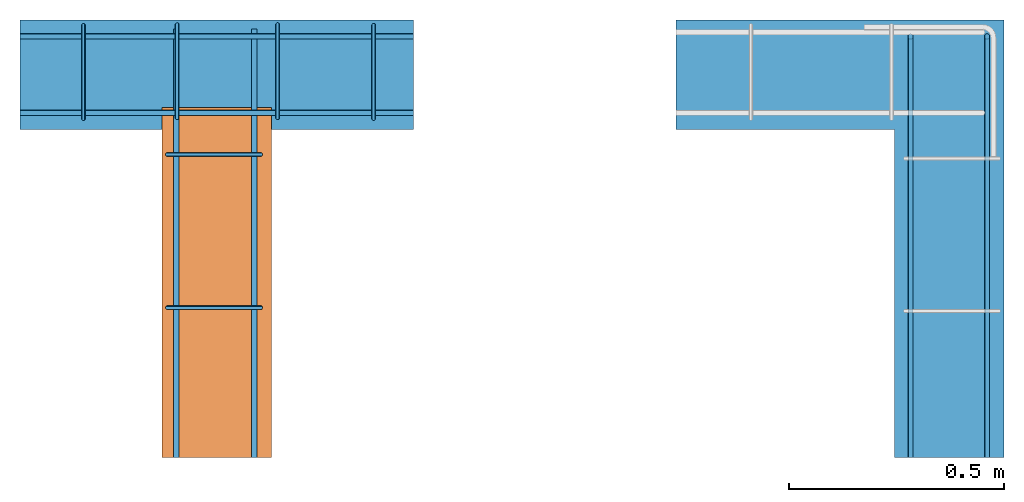
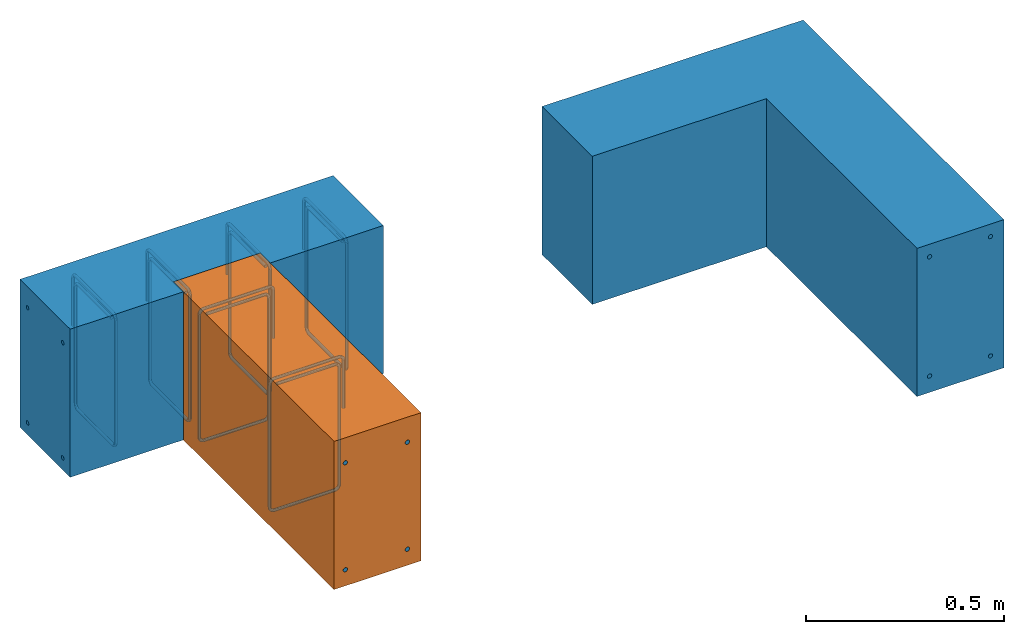
# One storey, part 1 of 2: 12 reinforcing bars, 2 walls, 1 proxy, 2 elements without a shape of their own.
"""IFC4 building model written with IfcOpenShell, lengths in metres."""

from ifc_helpers import new_model, entity, si_unit, converted_unit, direction, frame, frame_2d, origin_with_axes, origin_2d_with_axis, place, context, subcontext, project, spatial, polyline, rectangle, outline, extrude, element, aggregate, save


model = new_model("IFC4")

# Units and contexts
model_context = context("Model", 3, precision=1e-05, world=origin_with_axes(), true_north=direction((0.0, 1.0)))
body_context = subcontext(model_context, "Body", "Model", "MODEL_VIEW")
ifc_project = project(units=[si_unit("LENGTHUNIT", "METRE"), si_unit("AREAUNIT", "SQUARE_METRE"), si_unit("VOLUMEUNIT", "CUBIC_METRE"), converted_unit("PLANEANGLEUNIT", "DEGREE", entity("IfcPlaneAngleMeasure", 0.017453292519943295), si_unit("PLANEANGLEUNIT", "RADIAN"), dimensions=[0, 0, 0, 0, 0, 0, 0])], contexts=[model_context])

# Site, building, storey
site = spatial("IfcSite", under=ifc_project, CompositionType="ELEMENT")
building = spatial("IfcBuilding", under=site, Name="Default Building", CompositionType="ELEMENT")
storey = spatial("IfcBuildingStorey", under=building, Name="Detail 2", CompositionType="COMPLEX")

# Wall
placement = place(None, origin_with_axes())
wall_1 = element("IfcWall", 1, at=placement, inside=storey, Name="Wall", PredefinedType="MOVABLE", context=body_context, shape_type="SweptSolid", body=[
    extrude(rectangle(XDim=0.9144, YDim=0.254, at=origin_2d_with_axis()), frame((3.2004, -0.126999998486042, 0.0254), z_axis=(0.0, 0.0, 1.0), x_axis=(1.0, 0.0, 0.0)), (0.0, 0.0, -1.0), 0.4572),
])

element("IfcWall", 2, at=placement, inside=storey, Name="Wall", PredefinedType="MOVABLE", context=body_context, shape_type="SweptSolid", body=[
    extrude(outline(polyline([(-0.507999999999905, 0.380999999999986), (0.254, 0.381), (0.254, -0.635), (0.0, -0.635000000000024), (9.45910016980633e-14, 0.126999999999953), (-0.507999999999811, 0.126999999999962), (-0.507999999999905, 0.380999999999986)])), frame((4.7752, -0.380999998486042, 0.0254), z_axis=(0.0, 0.0, 1.0), x_axis=(1.0, 0.0, 0.0)), (0.0, 0.0, -1.0), 0.4572),
])

# Proxy
proxy = element("IfcBuildingElementProxy", 3, at=placement, Name="Wall", PredefinedType="ELEMENT", context=body_context, shape_type="SweptSolid", body=[
    extrude(rectangle(XDim=0.812800003051763, YDim=0.254, at=frame_2d((0.0, 0.0), x_axis=(-1.20147944482968e-07, 0.999999999999993))), frame((3.20039995117188, -0.609599998474121, 0.0254), z_axis=(0.0, 0.0, 1.0), x_axis=(1.0, 0.0, 0.0)), (0.0, 0.0, -1.0), 0.4572),
])

aggregate(wall_1, [proxy])

# Assembly, reinforcing bars
assembly_1 = element("IfcElementAssembly", 4, inside=storey, Name="Compound002")
reinforcing_bar_1 = element("IfcReinforcingBar", 5, at=placement, Name="Rebar", context=body_context, shape_type="SweptSolid", body=[
    entity("IfcSweptDiskSolid", entity("IfcCompositeCurve", [entity("IfcCompositeCurveSegment", "CONTINUOUS", True, entity("IfcPolyline", [entity("IfcCartesianPoint", [2.7432, -0.0381000008277714, -0.0392876983642576]), entity("IfcCartesianPoint", [3.6576, -0.0381000008277714, -0.0392876983642576])]))], False), 0.00635),
    entity("IfcSweptDiskSolid", entity("IfcCompositeCurve", [entity("IfcCompositeCurveSegment", "CONTINUOUS", True, entity("IfcPolyline", [entity("IfcCartesianPoint", [2.7432, -0.0381000008277714, -0.394887698364258]), entity("IfcCartesianPoint", [3.6576, -0.0381000008277714, -0.394887698364258])]))], False), 0.00635),
])
reinforcing_bar_2 = element("IfcReinforcingBar", 6, at=placement, Name="Rebar", context=body_context, shape_type="SweptSolid", body=[
    entity("IfcSweptDiskSolid", entity("IfcCompositeCurve", [entity("IfcCompositeCurveSegment", "CONTINUOUS", True, entity("IfcPolyline", [entity("IfcCartesianPoint", [2.7432, -0.215900000827771, -0.0392876983642576]), entity("IfcCartesianPoint", [3.6576, -0.215900000827771, -0.0392876983642576])]))], False), 0.00635),
    entity("IfcSweptDiskSolid", entity("IfcCompositeCurve", [entity("IfcCompositeCurveSegment", "CONTINUOUS", True, entity("IfcPolyline", [entity("IfcCartesianPoint", [2.7432, -0.215900000827771, -0.394887698364258]), entity("IfcCartesianPoint", [3.6576, -0.215900000827771, -0.394887698364258])]))], False), 0.00635),
])
reinforcing_bar_3 = element("IfcReinforcingBar", 7, at=placement, Name="Rebar", context=body_context, shape_type="SweptSolid", body=[
    entity("IfcSweptDiskSolid", entity("IfcCompositeCurve", [entity("IfcCompositeCurveSegment", "CONTINUOUS", True, entity("IfcPolyline", [entity("IfcCartesianPoint", [3.28751567382813, -1.01600001797707, -0.0519552146911619]), entity("IfcCartesianPoint", [3.28751567382813, -0.0205375487182828, -0.0519552146911619])]))], False), 0.00635),
    entity("IfcSweptDiskSolid", entity("IfcCompositeCurve", [entity("IfcCompositeCurveSegment", "CONTINUOUS", True, entity("IfcPolyline", [entity("IfcCartesianPoint", [3.28751567382813, -1.01600001797707, -0.382155214691162]), entity("IfcCartesianPoint", [3.28751567382813, -0.0205375487182828, -0.382155214691162])]))], False), 0.00635),
])
ifc_direction_1 = entity("IfcDirection", [1.0, 0.0, 0.0])
reinforcing_bar_4 = element("IfcReinforcingBar", 8, at=placement, Name="Stirrup", context=body_context, shape_type="SweptSolid", body=[
    entity("IfcSweptDiskSolid", entity("IfcCompositeCurve", [entity("IfcCompositeCurveSegment", "CONTINUOUS", True, entity("IfcPolyline", [entity("IfcCartesianPoint", [3.56481088867188, -0.0126999984860419, -0.160908578]), entity("IfcCartesianPoint", [3.56481088867188, -0.0126999984860419, -0.0142800000000001])])), entity("IfcCompositeCurveSegment", "CONTINUOUS", True, entity("IfcTrimmedCurve", entity("IfcCircle", entity("IfcAxis2Placement3D", entity("IfcCartesianPoint", [3.56481088867167, -0.0269799984860419, -0.0142799999999994]), ifc_direction_1, entity("IfcDirection", [0.0, 1.0, 9.95157893221428e-16])), 0.01428), [entity("IfcParameterValue", 0.0)], [entity("IfcParameterValue", 89.9999999999999)], True, "PARAMETER")), entity("IfcCompositeCurveSegment", "CONTINUOUS", True, entity("IfcPolyline", [entity("IfcCartesianPoint", [3.56481088867188, -0.0269799984860419, -5.6843418860808e-17]), entity("IfcCartesianPoint", [3.56481088867188, -0.214319998486042, -5.6843418860808e-17])])), entity("IfcCompositeCurveSegment", "CONTINUOUS", True, entity("IfcTrimmedCurve", entity("IfcCircle", entity("IfcAxis2Placement3D", entity("IfcCartesianPoint", [3.56481088867167, -0.214319998486042, -0.0142799999999994]), ifc_direction_1, entity("IfcDirection", [0.0, -1.99031578644285e-15, 1.0])), 0.01428), [entity("IfcParameterValue", 0.0)], [entity("IfcParameterValue", 90.0000000000025)], True, "PARAMETER")), entity("IfcCompositeCurveSegment", "CONTINUOUS", True, entity("IfcPolyline", [entity("IfcCartesianPoint", [3.56481088867188, -0.228599998486042, -0.0142800000000001]), entity("IfcCartesianPoint", [3.56481088867188, -0.228599998486042, -0.39212])])), entity("IfcCompositeCurveSegment", "CONTINUOUS", True, entity("IfcTrimmedCurve", entity("IfcCircle", entity("IfcAxis2Placement3D", entity("IfcCartesianPoint", [3.56481088867167, -0.214319998486042, -0.392119999999998]), ifc_direction_1, entity("IfcDirection", [0.0, -1.0, 0.0])), 0.01428), [entity("IfcParameterValue", 0.0)], [entity("IfcParameterValue", 90.0000000000001)], True, "PARAMETER")), entity("IfcCompositeCurveSegment", "CONTINUOUS", True, entity("IfcPolyline", [entity("IfcCartesianPoint", [3.56481088867188, -0.214319998486042, -0.4064]), entity("IfcCartesianPoint", [3.56481088867188, -0.0396799984860419, -0.4064])])), entity("IfcCompositeCurveSegment", "CONTINUOUS", True, entity("IfcTrimmedCurve", entity("IfcCircle", entity("IfcAxis2Placement3D", entity("IfcCartesianPoint", [3.56481088867167, -0.0396799984860419, -0.392119999999998]), ifc_direction_1, entity("IfcDirection", [0.0, -1.99031578644287e-15, -1.0])), 0.0142799999999999), [entity("IfcParameterValue", 0.0)], [entity("IfcParameterValue", 89.9999999999939)], True, "PARAMETER")), entity("IfcCompositeCurveSegment", "CONTINUOUS", True, entity("IfcPolyline", [entity("IfcCartesianPoint", [3.56481088867188, -0.025399998486042, -0.39212]), entity("IfcCartesianPoint", [3.56481088867188, -0.0253999984860419, -0.0331541470000001])])), entity("IfcCompositeCurveSegment", "CONTINUOUS", True, entity("IfcTrimmedCurve", entity("IfcCircle", entity("IfcAxis2Placement3D", entity("IfcCartesianPoint", [3.56481088867167, -0.0396799984860419, -0.0331541469999976]), ifc_direction_1, entity("IfcDirection", [0.0, 1.0, 4.97578946610714e-16])), 0.01428), [entity("IfcParameterValue", 0.0)], [entity("IfcParameterValue", 90.0)], True, "PARAMETER")), entity("IfcCompositeCurveSegment", "CONTINUOUS", True, entity("IfcPolyline", [entity("IfcCartesianPoint", [3.56481088867188, -0.0396799984860419, -0.0188741470000001]), entity("IfcCartesianPoint", [3.56481088867188, -0.208265043486042, -0.0188741470000001])]))], False), 0.00476),
])
reinforcing_bar_5 = element("IfcReinforcingBar", 9, at=placement, Name="Rebar", context=body_context, shape_type="SweptSolid", body=[
    entity("IfcSweptDiskSolid", entity("IfcCompositeCurve", [entity("IfcCompositeCurveSegment", "CONTINUOUS", True, entity("IfcPolyline", [entity("IfcCartesianPoint", [3.10630766601563, -1.01600001797707, -0.0519552146911619]), entity("IfcCartesianPoint", [3.10630766601563, -0.0205375487182828, -0.0519552146911619])]))], False), 0.00635),
    entity("IfcSweptDiskSolid", entity("IfcCompositeCurve", [entity("IfcCompositeCurveSegment", "CONTINUOUS", True, entity("IfcPolyline", [entity("IfcCartesianPoint", [3.10630766601563, -1.01600001797707, -0.382155214691162]), entity("IfcCartesianPoint", [3.10630766601563, -0.0205375487182828, -0.382155214691162])]))], False), 0.00635),
])
ifc_direction_2 = entity("IfcDirection", [1.0, 0.0, 0.0])
reinforcing_bar_6 = element("IfcReinforcingBar", 10, at=placement, Name="Stirrup", context=body_context, shape_type="SweptSolid", body=[
    entity("IfcSweptDiskSolid", entity("IfcCompositeCurve", [entity("IfcCompositeCurveSegment", "CONTINUOUS", True, entity("IfcPolyline", [entity("IfcCartesianPoint", [3.3417212890625, -0.0110340164505546, -0.160908578]), entity("IfcCartesianPoint", [3.3417212890625, -0.0110340164505546, -0.0142800000000001])])), entity("IfcCompositeCurveSegment", "CONTINUOUS", True, entity("IfcTrimmedCurve", entity("IfcCircle", entity("IfcAxis2Placement3D", entity("IfcCartesianPoint", [3.34172128906266, -0.0253140164505545, -0.0142799999999994]), ifc_direction_2, entity("IfcDirection", [0.0, 1.0, 9.95157893221428e-16])), 0.01428), [entity("IfcParameterValue", 0.0)], [entity("IfcParameterValue", 90.0000000000002)], True, "PARAMETER")), entity("IfcCompositeCurveSegment", "CONTINUOUS", True, entity("IfcPolyline", [entity("IfcCartesianPoint", [3.3417212890625, -0.0253140164505546, -5.6843418860808e-17]), entity("IfcCartesianPoint", [3.3417212890625, -0.212654016450555, -5.6843418860808e-17])])), entity("IfcCompositeCurveSegment", "CONTINUOUS", True, entity("IfcTrimmedCurve", entity("IfcCircle", entity("IfcAxis2Placement3D", entity("IfcCartesianPoint", [3.34172128906266, -0.212654016450555, -0.0142799999999994]), ifc_direction_2, entity("IfcDirection", [0.0, -1.99031578644285e-15, 1.0])), 0.01428), [entity("IfcParameterValue", 0.0)], [entity("IfcParameterValue", 90.0000000000025)], True, "PARAMETER")), entity("IfcCompositeCurveSegment", "CONTINUOUS", True, entity("IfcPolyline", [entity("IfcCartesianPoint", [3.3417212890625, -0.226934016450555, -0.0142800000000001]), entity("IfcCartesianPoint", [3.3417212890625, -0.226934016450555, -0.39212])])), entity("IfcCompositeCurveSegment", "CONTINUOUS", True, entity("IfcTrimmedCurve", entity("IfcCircle", entity("IfcAxis2Placement3D", entity("IfcCartesianPoint", [3.34172128906266, -0.212654016450555, -0.392119999999998]), ifc_direction_2, entity("IfcDirection", [0.0, -1.0, 0.0])), 0.01428), [entity("IfcParameterValue", 0.0)], [entity("IfcParameterValue", 90.0)], True, "PARAMETER")), entity("IfcCompositeCurveSegment", "CONTINUOUS", True, entity("IfcPolyline", [entity("IfcCartesianPoint", [3.3417212890625, -0.212654016450555, -0.4064]), entity("IfcCartesianPoint", [3.3417212890625, -0.0380140164505546, -0.4064])])), entity("IfcCompositeCurveSegment", "CONTINUOUS", True, entity("IfcTrimmedCurve", entity("IfcCircle", entity("IfcAxis2Placement3D", entity("IfcCartesianPoint", [3.34172128906266, -0.0380140164505545, -0.392119999999998]), ifc_direction_2, entity("IfcDirection", [0.0, -1.99031578644287e-15, -1.0])), 0.0142799999999999), [entity("IfcParameterValue", 0.0)], [entity("IfcParameterValue", 89.9999999999939)], True, "PARAMETER")), entity("IfcCompositeCurveSegment", "CONTINUOUS", True, entity("IfcPolyline", [entity("IfcCartesianPoint", [3.3417212890625, -0.0237340164505546, -0.39212]), entity("IfcCartesianPoint", [3.3417212890625, -0.0237340164505546, -0.0331541470000001])])), entity("IfcCompositeCurveSegment", "CONTINUOUS", True, entity("IfcTrimmedCurve", entity("IfcCircle", entity("IfcAxis2Placement3D", entity("IfcCartesianPoint", [3.34172128906266, -0.0380140164505545, -0.0331541469999976]), ifc_direction_2, entity("IfcDirection", [0.0, 1.0, 4.97578946610714e-16])), 0.01428), [entity("IfcParameterValue", 0.0)], [entity("IfcParameterValue", 90.0000000000005)], True, "PARAMETER")), entity("IfcCompositeCurveSegment", "CONTINUOUS", True, entity("IfcPolyline", [entity("IfcCartesianPoint", [3.3417212890625, -0.0380140164505546, -0.0188741470000001]), entity("IfcCartesianPoint", [3.3417212890625, -0.206599061450555, -0.0188741470000001])]))], False), 0.00476),
])
ifc_direction_3 = entity("IfcDirection", [1.0, 0.0, 0.0])
reinforcing_bar_7 = element("IfcReinforcingBar", 11, at=placement, Name="Stirrup", context=body_context, shape_type="SweptSolid", body=[
    entity("IfcSweptDiskSolid", entity("IfcCompositeCurve", [entity("IfcCompositeCurveSegment", "CONTINUOUS", True, entity("IfcPolyline", [entity("IfcCartesianPoint", [3.10840268554687, -0.0110340164505546, -0.160908578]), entity("IfcCartesianPoint", [3.10840268554687, -0.0110340164505546, -0.0142800000000001])])), entity("IfcCompositeCurveSegment", "CONTINUOUS", True, entity("IfcTrimmedCurve", entity("IfcCircle", entity("IfcAxis2Placement3D", entity("IfcCartesianPoint", [3.10840268554693, -0.0253140164505545, -0.0142799999999994]), ifc_direction_3, entity("IfcDirection", [0.0, 1.0, 9.95157893221428e-16])), 0.01428), [entity("IfcParameterValue", 0.0)], [entity("IfcParameterValue", 90.0000000000002)], True, "PARAMETER")), entity("IfcCompositeCurveSegment", "CONTINUOUS", True, entity("IfcPolyline", [entity("IfcCartesianPoint", [3.10840268554687, -0.0253140164505546, -5.6843418860808e-17]), entity("IfcCartesianPoint", [3.10840268554687, -0.212654016450555, -5.6843418860808e-17])])), entity("IfcCompositeCurveSegment", "CONTINUOUS", True, entity("IfcTrimmedCurve", entity("IfcCircle", entity("IfcAxis2Placement3D", entity("IfcCartesianPoint", [3.10840268554693, -0.212654016450555, -0.0142799999999994]), ifc_direction_3, entity("IfcDirection", [0.0, -1.99031578644285e-15, 1.0])), 0.01428), [entity("IfcParameterValue", 0.0)], [entity("IfcParameterValue", 90.0000000000025)], True, "PARAMETER")), entity("IfcCompositeCurveSegment", "CONTINUOUS", True, entity("IfcPolyline", [entity("IfcCartesianPoint", [3.10840268554687, -0.226934016450555, -0.0142800000000001]), entity("IfcCartesianPoint", [3.10840268554687, -0.226934016450555, -0.39212])])), entity("IfcCompositeCurveSegment", "CONTINUOUS", True, entity("IfcTrimmedCurve", entity("IfcCircle", entity("IfcAxis2Placement3D", entity("IfcCartesianPoint", [3.10840268554693, -0.212654016450555, -0.392119999999998]), ifc_direction_3, entity("IfcDirection", [0.0, -1.0, 0.0])), 0.01428), [entity("IfcParameterValue", 0.0)], [entity("IfcParameterValue", 90.0)], True, "PARAMETER")), entity("IfcCompositeCurveSegment", "CONTINUOUS", True, entity("IfcPolyline", [entity("IfcCartesianPoint", [3.10840268554687, -0.212654016450555, -0.4064]), entity("IfcCartesianPoint", [3.10840268554687, -0.0380140164505546, -0.4064])])), entity("IfcCompositeCurveSegment", "CONTINUOUS", True, entity("IfcTrimmedCurve", entity("IfcCircle", entity("IfcAxis2Placement3D", entity("IfcCartesianPoint", [3.10840268554693, -0.0380140164505545, -0.392119999999998]), ifc_direction_3, entity("IfcDirection", [0.0, -1.99031578644287e-15, -1.0])), 0.0142799999999999), [entity("IfcParameterValue", 0.0)], [entity("IfcParameterValue", 89.9999999999939)], True, "PARAMETER")), entity("IfcCompositeCurveSegment", "CONTINUOUS", True, entity("IfcPolyline", [entity("IfcCartesianPoint", [3.10840268554687, -0.0237340164505546, -0.39212]), entity("IfcCartesianPoint", [3.10840268554687, -0.0237340164505546, -0.0331541470000001])])), entity("IfcCompositeCurveSegment", "CONTINUOUS", True, entity("IfcTrimmedCurve", entity("IfcCircle", entity("IfcAxis2Placement3D", entity("IfcCartesianPoint", [3.10840268554693, -0.0380140164505545, -0.0331541469999976]), ifc_direction_3, entity("IfcDirection", [0.0, 1.0, 4.97578946610714e-16])), 0.01428), [entity("IfcParameterValue", 0.0)], [entity("IfcParameterValue", 90.0000000000005)], True, "PARAMETER")), entity("IfcCompositeCurveSegment", "CONTINUOUS", True, entity("IfcPolyline", [entity("IfcCartesianPoint", [3.10840268554687, -0.0380140164505546, -0.0188741470000001]), entity("IfcCartesianPoint", [3.10840268554687, -0.206599061450555, -0.0188741470000001])]))], False), 0.00476),
])
ifc_direction_4 = entity("IfcDirection", [1.0, 0.0, 0.0])
reinforcing_bar_8 = element("IfcReinforcingBar", 12, at=placement, Name="Stirrup", context=body_context, shape_type="SweptSolid", body=[
    entity("IfcSweptDiskSolid", entity("IfcCompositeCurve", [entity("IfcCompositeCurveSegment", "CONTINUOUS", True, entity("IfcPolyline", [entity("IfcCartesianPoint", [2.89089004135132, -0.0126999984860419, -0.160908578]), entity("IfcCartesianPoint", [2.89089004135132, -0.0126999984860419, -0.0142800000000002])])), entity("IfcCompositeCurveSegment", "CONTINUOUS", True, entity("IfcTrimmedCurve", entity("IfcCircle", entity("IfcAxis2Placement3D", entity("IfcCartesianPoint", [2.89089004135121, -0.0269799984860419, -0.0142799999999994]), ifc_direction_4, entity("IfcDirection", [0.0, 1.0, 9.95157893221428e-16])), 0.01428), [entity("IfcParameterValue", 0.0)], [entity("IfcParameterValue", 89.9999999999999)], True, "PARAMETER")), entity("IfcCompositeCurveSegment", "CONTINUOUS", True, entity("IfcPolyline", [entity("IfcCartesianPoint", [2.89089004135132, -0.0269799984860419, -1.49213974509621e-16]), entity("IfcCartesianPoint", [2.89089004135132, -0.214319998486042, -1.49213974509621e-16])])), entity("IfcCompositeCurveSegment", "CONTINUOUS", True, entity("IfcTrimmedCurve", entity("IfcCircle", entity("IfcAxis2Placement3D", entity("IfcCartesianPoint", [2.89089004135121, -0.214319998486042, -0.0142799999999994]), ifc_direction_4, entity("IfcDirection", [0.0, -1.99031578644285e-15, 1.0])), 0.01428), [entity("IfcParameterValue", 0.0)], [entity("IfcParameterValue", 90.0000000000029)], True, "PARAMETER")), entity("IfcCompositeCurveSegment", "CONTINUOUS", True, entity("IfcPolyline", [entity("IfcCartesianPoint", [2.89089004135132, -0.228599998486042, -0.0142800000000002]), entity("IfcCartesianPoint", [2.89089004135132, -0.228599998486042, -0.39212])])), entity("IfcCompositeCurveSegment", "CONTINUOUS", True, entity("IfcTrimmedCurve", entity("IfcCircle", entity("IfcAxis2Placement3D", entity("IfcCartesianPoint", [2.89089004135121, -0.214319998486042, -0.392119999999998]), ifc_direction_4, entity("IfcDirection", [0.0, -1.0, 0.0])), 0.01428), [entity("IfcParameterValue", 0.0)], [entity("IfcParameterValue", 90.0000000000001)], True, "PARAMETER")), entity("IfcCompositeCurveSegment", "CONTINUOUS", True, entity("IfcPolyline", [entity("IfcCartesianPoint", [2.89089004135132, -0.214319998486042, -0.4064]), entity("IfcCartesianPoint", [2.89089004135132, -0.0396799984860419, -0.4064])])), entity("IfcCompositeCurveSegment", "CONTINUOUS", True, entity("IfcTrimmedCurve", entity("IfcCircle", entity("IfcAxis2Placement3D", entity("IfcCartesianPoint", [2.89089004135121, -0.0396799984860419, -0.392119999999998]), ifc_direction_4, entity("IfcDirection", [0.0, -1.99031578644287e-15, -1.0])), 0.0142799999999999), [entity("IfcParameterValue", 0.0)], [entity("IfcParameterValue", 89.9999999999934)], True, "PARAMETER")), entity("IfcCompositeCurveSegment", "CONTINUOUS", True, entity("IfcPolyline", [entity("IfcCartesianPoint", [2.89089004135132, -0.025399998486042, -0.39212]), entity("IfcCartesianPoint", [2.89089004135132, -0.0253999984860419, -0.0331541470000002])])), entity("IfcCompositeCurveSegment", "CONTINUOUS", True, entity("IfcTrimmedCurve", entity("IfcCircle", entity("IfcAxis2Placement3D", entity("IfcCartesianPoint", [2.89089004135121, -0.0396799984860419, -0.0331541469999976]), ifc_direction_4, entity("IfcDirection", [0.0, 1.0, 4.97578946610714e-16])), 0.01428), [entity("IfcParameterValue", 0.0)], [entity("IfcParameterValue", 90.0)], True, "PARAMETER")), entity("IfcCompositeCurveSegment", "CONTINUOUS", True, entity("IfcPolyline", [entity("IfcCartesianPoint", [2.89089004135132, -0.0396799984860419, -0.0188741470000002]), entity("IfcCartesianPoint", [2.89089004135132, -0.208265043486042, -0.0188741470000002])]))], False), 0.00476),
])
ifc_direction_5 = entity("IfcDirection", [2.22044604925031e-16, -1.0, 0.0])
reinforcing_bar_9 = element("IfcReinforcingBar", 13, at=placement, Name="Stirrup", context=body_context, shape_type="SweptSolid", body=[
    entity("IfcSweptDiskSolid", entity("IfcCompositeCurve", [entity("IfcCompositeCurveSegment", "CONTINUOUS", True, entity("IfcPolyline", [entity("IfcCartesianPoint", [3.302, -0.312578255093097, -0.160908578]), entity("IfcCartesianPoint", [3.302, -0.312578255093097, -0.0142800000000001])])), entity("IfcCompositeCurveSegment", "CONTINUOUS", True, entity("IfcTrimmedCurve", entity("IfcCircle", entity("IfcAxis2Placement3D", entity("IfcCartesianPoint", [3.28771999999981, -0.312578255093115, -0.0142799999999994]), ifc_direction_5, entity("IfcDirection", [1.0, 2.22044604925031e-16, 9.95157893221428e-16])), 0.01428), [entity("IfcParameterValue", 0.0)], [entity("IfcParameterValue", 89.9999999992284)], True, "PARAMETER")), entity("IfcCompositeCurveSegment", "CONTINUOUS", True, entity("IfcPolyline", [entity("IfcCartesianPoint", [3.28772, -0.312578255093097, -5.6843418860808e-17]), entity("IfcCartesianPoint", [3.10038, -0.312578255093097, -5.6843418860808e-17])])), entity("IfcCompositeCurveSegment", "CONTINUOUS", True, entity("IfcTrimmedCurve", entity("IfcCircle", entity("IfcAxis2Placement3D", entity("IfcCartesianPoint", [3.10037999999986, -0.312578255093115, -0.0142799999999994]), ifc_direction_5, entity("IfcDirection", [-1.99031578644285e-15, -4.41938882476756e-31, 1.0])), 0.01428), [entity("IfcParameterValue", 0.0)], [entity("IfcParameterValue", 90.0000000000025)], True, "PARAMETER")), entity("IfcCompositeCurveSegment", "CONTINUOUS", True, entity("IfcPolyline", [entity("IfcCartesianPoint", [3.0861, -0.312578255093097, -0.0142800000000001]), entity("IfcCartesianPoint", [3.0861, -0.312578255093097, -0.39212])])), entity("IfcCompositeCurveSegment", "CONTINUOUS", True, entity("IfcTrimmedCurve", entity("IfcCircle", entity("IfcAxis2Placement3D", entity("IfcCartesianPoint", [3.10037999999986, -0.312578255093115, -0.392119999999998]), ifc_direction_5, entity("IfcDirection", [-1.0, -2.22044604925031e-16, 0.0])), 0.01428), [entity("IfcParameterValue", 0.0)], [entity("IfcParameterValue", 90.0000000005684)], True, "PARAMETER")), entity("IfcCompositeCurveSegment", "CONTINUOUS", True, entity("IfcPolyline", [entity("IfcCartesianPoint", [3.10038, -0.312578255093097, -0.4064]), entity("IfcCartesianPoint", [3.27502, -0.312578255093097, -0.4064])])), entity("IfcCompositeCurveSegment", "CONTINUOUS", True, entity("IfcTrimmedCurve", entity("IfcCircle", entity("IfcAxis2Placement3D", entity("IfcCartesianPoint", [3.27502000000004, -0.312578255093115, -0.392119999999998]), ifc_direction_5, entity("IfcDirection", [-1.99031578644287e-15, -4.4193888247676e-31, -1.0])), 0.0142799999999999), [entity("IfcParameterValue", 0.0)], [entity("IfcParameterValue", 89.9999999999939)], True, "PARAMETER")), entity("IfcCompositeCurveSegment", "CONTINUOUS", True, entity("IfcPolyline", [entity("IfcCartesianPoint", [3.2893, -0.312578255093097, -0.39212]), entity("IfcCartesianPoint", [3.2893, -0.312578255093097, -0.0331541470000001])])), entity("IfcCompositeCurveSegment", "CONTINUOUS", True, entity("IfcTrimmedCurve", entity("IfcCircle", entity("IfcAxis2Placement3D", entity("IfcCartesianPoint", [3.27502000000004, -0.312578255093115, -0.0331541469999976]), ifc_direction_5, entity("IfcDirection", [1.0, 2.22044604925031e-16, 4.97578946610714e-16])), 0.01428), [entity("IfcParameterValue", 0.0)], [entity("IfcParameterValue", 90.0000000001586)], True, "PARAMETER")), entity("IfcCompositeCurveSegment", "CONTINUOUS", True, entity("IfcPolyline", [entity("IfcCartesianPoint", [3.27502, -0.312578255093097, -0.0188741470000001]), entity("IfcCartesianPoint", [3.106434955, -0.312578255093097, -0.0188741470000001])]))], False), 0.00476),
])
ifc_direction_6 = entity("IfcDirection", [2.22044604925031e-16, -1.0, 0.0])
reinforcing_bar_10 = element("IfcReinforcingBar", 14, at=placement, Name="Stirrup", context=body_context, shape_type="SweptSolid", body=[
    entity("IfcSweptDiskSolid", entity("IfcCompositeCurve", [entity("IfcCompositeCurveSegment", "CONTINUOUS", True, entity("IfcPolyline", [entity("IfcCartesianPoint", [3.302, -0.668178255093097, -0.160908578]), entity("IfcCartesianPoint", [3.302, -0.668178255093097, -0.0142800000000001])])), entity("IfcCompositeCurveSegment", "CONTINUOUS", True, entity("IfcTrimmedCurve", entity("IfcCircle", entity("IfcAxis2Placement3D", entity("IfcCartesianPoint", [3.28771999999981, -0.668178255093153, -0.0142799999999994]), ifc_direction_6, entity("IfcDirection", [1.0, 2.22044604925031e-16, 9.95157893221428e-16])), 0.01428), [entity("IfcParameterValue", 0.0)], [entity("IfcParameterValue", 89.9999999992284)], True, "PARAMETER")), entity("IfcCompositeCurveSegment", "CONTINUOUS", True, entity("IfcPolyline", [entity("IfcCartesianPoint", [3.28772, -0.668178255093097, -5.6843418860808e-17]), entity("IfcCartesianPoint", [3.10038, -0.668178255093097, -5.6843418860808e-17])])), entity("IfcCompositeCurveSegment", "CONTINUOUS", True, entity("IfcTrimmedCurve", entity("IfcCircle", entity("IfcAxis2Placement3D", entity("IfcCartesianPoint", [3.10037999999986, -0.668178255093153, -0.0142799999999994]), ifc_direction_6, entity("IfcDirection", [-1.99031578644285e-15, -4.41938882476756e-31, 1.0])), 0.01428), [entity("IfcParameterValue", 0.0)], [entity("IfcParameterValue", 90.0000000000025)], True, "PARAMETER")), entity("IfcCompositeCurveSegment", "CONTINUOUS", True, entity("IfcPolyline", [entity("IfcCartesianPoint", [3.0861, -0.668178255093097, -0.0142800000000001]), entity("IfcCartesianPoint", [3.0861, -0.668178255093097, -0.39212])])), entity("IfcCompositeCurveSegment", "CONTINUOUS", True, entity("IfcTrimmedCurve", entity("IfcCircle", entity("IfcAxis2Placement3D", entity("IfcCartesianPoint", [3.10037999999986, -0.668178255093153, -0.392119999999998]), ifc_direction_6, entity("IfcDirection", [-1.0, -2.22044604925031e-16, 0.0])), 0.01428), [entity("IfcParameterValue", 0.0)], [entity("IfcParameterValue", 90.0000000005684)], True, "PARAMETER")), entity("IfcCompositeCurveSegment", "CONTINUOUS", True, entity("IfcPolyline", [entity("IfcCartesianPoint", [3.10038, -0.668178255093097, -0.4064]), entity("IfcCartesianPoint", [3.27502, -0.668178255093097, -0.4064])])), entity("IfcCompositeCurveSegment", "CONTINUOUS", True, entity("IfcTrimmedCurve", entity("IfcCircle", entity("IfcAxis2Placement3D", entity("IfcCartesianPoint", [3.27502000000004, -0.668178255093153, -0.392119999999998]), ifc_direction_6, entity("IfcDirection", [-1.99031578644287e-15, -4.4193888247676e-31, -1.0])), 0.0142799999999999), [entity("IfcParameterValue", 0.0)], [entity("IfcParameterValue", 89.9999999999939)], True, "PARAMETER")), entity("IfcCompositeCurveSegment", "CONTINUOUS", True, entity("IfcPolyline", [entity("IfcCartesianPoint", [3.2893, -0.668178255093097, -0.39212]), entity("IfcCartesianPoint", [3.2893, -0.668178255093097, -0.0331541470000001])])), entity("IfcCompositeCurveSegment", "CONTINUOUS", True, entity("IfcTrimmedCurve", entity("IfcCircle", entity("IfcAxis2Placement3D", entity("IfcCartesianPoint", [3.27502000000004, -0.668178255093153, -0.0331541469999976]), ifc_direction_6, entity("IfcDirection", [1.0, 2.22044604925031e-16, 4.97578946610714e-16])), 0.01428), [entity("IfcParameterValue", 0.0)], [entity("IfcParameterValue", 90.0000000001586)], True, "PARAMETER")), entity("IfcCompositeCurveSegment", "CONTINUOUS", True, entity("IfcPolyline", [entity("IfcCartesianPoint", [3.27502, -0.668178255093097, -0.0188741470000001]), entity("IfcCartesianPoint", [3.106434955, -0.668178255093097, -0.0188741470000001])]))], False), 0.00476),
])
aggregate(assembly_1, [reinforcing_bar_1, reinforcing_bar_2, reinforcing_bar_3, reinforcing_bar_4, reinforcing_bar_5, reinforcing_bar_6, reinforcing_bar_7, reinforcing_bar_8, reinforcing_bar_9, reinforcing_bar_10])

assembly_2 = element("IfcElementAssembly", 15, inside=storey, Name="Compound003")
reinforcing_bar_11 = element("IfcReinforcingBar", 16, at=placement, Name="Rebar", context=body_context, shape_type="SweptSolid", body=[
    entity("IfcSweptDiskSolid", entity("IfcCompositeCurve", [entity("IfcCompositeCurveSegment", "CONTINUOUS", True, entity("IfcPolyline", [entity("IfcCartesianPoint", [4.9897856136322, -1.01599999776215, -0.381555041503906]), entity("IfcCartesianPoint", [4.9897856136322, -0.063499997762146, -0.381555041503906])])), entity("IfcCompositeCurveSegment", "CONTINUOUS", True, entity("IfcTrimmedCurve", entity("IfcCircle", entity("IfcAxis2Placement3D", entity("IfcCartesianPoint", [4.9897856136322, -0.063499997762146, -0.356155041503905]), entity("IfcDirection", [1.0, 0.0, 0.0]), entity("IfcDirection", [0.0, -2.79741234551221e-16, -1.0])), 0.0254), [entity("IfcParameterValue", 0.0)], [entity("IfcParameterValue", 89.9999999999979)], True, "PARAMETER")), entity("IfcCompositeCurveSegment", "CONTINUOUS", True, entity("IfcPolyline", [entity("IfcCartesianPoint", [4.9897856136322, -0.038099997762146, -0.356155041503906]), entity("IfcCartesianPoint", [4.9897856136322, -0.038099997762146, -0.346084259503906])]))], False), 0.00635),
    entity("IfcSweptDiskSolid", entity("IfcCompositeCurve", [entity("IfcCompositeCurveSegment", "CONTINUOUS", True, entity("IfcPolyline", [entity("IfcCartesianPoint", [4.8119856136322, -1.01599999776215, -0.381555041503906]), entity("IfcCartesianPoint", [4.8119856136322, -0.063499997762146, -0.381555041503906])])), entity("IfcCompositeCurveSegment", "CONTINUOUS", True, entity("IfcTrimmedCurve", entity("IfcCircle", entity("IfcAxis2Placement3D", entity("IfcCartesianPoint", [4.8119856136322, -0.063499997762146, -0.356155041503905]), entity("IfcDirection", [1.0, 0.0, 0.0]), entity("IfcDirection", [0.0, -2.79741234551221e-16, -1.0])), 0.0254), [entity("IfcParameterValue", 0.0)], [entity("IfcParameterValue", 89.9999999999979)], True, "PARAMETER")), entity("IfcCompositeCurveSegment", "CONTINUOUS", True, entity("IfcPolyline", [entity("IfcCartesianPoint", [4.8119856136322, -0.038099997762146, -0.356155041503906]), entity("IfcCartesianPoint", [4.8119856136322, -0.038099997762146, -0.346084259503906])]))], False), 0.00635),
])
reinforcing_bar_12 = element("IfcReinforcingBar", 17, at=placement, Name="Rebar", context=body_context, shape_type="SweptSolid", body=[
    entity("IfcSweptDiskSolid", entity("IfcCompositeCurve", [entity("IfcCompositeCurveSegment", "CONTINUOUS", True, entity("IfcPolyline", [entity("IfcCartesianPoint", [4.9897856136322, -1.01599999851751, -0.0132280303955079]), entity("IfcCartesianPoint", [4.9897856136322, -0.063499998517515, -0.0132280303955079])])), entity("IfcCompositeCurveSegment", "CONTINUOUS", True, entity("IfcTrimmedCurve", entity("IfcCircle", entity("IfcAxis2Placement3D", entity("IfcCartesianPoint", [4.9897856136322, -0.063499998517515, -0.0386280303955079]), entity("IfcDirection", [-1.0, 0.0, 0.0]), entity("IfcDirection", [0.0, 2.79741234551221e-16, 1.0])), 0.0254), [entity("IfcParameterValue", 0.0)], [entity("IfcParameterValue", 89.9999999999999)], True, "PARAMETER")), entity("IfcCompositeCurveSegment", "CONTINUOUS", True, entity("IfcPolyline", [entity("IfcCartesianPoint", [4.9897856136322, -0.038099998517515, -0.0386280303955079]), entity("IfcCartesianPoint", [4.9897856136322, -0.038099998517515, -0.303722580395508])]))], False), 0.00635),
    entity("IfcSweptDiskSolid", entity("IfcCompositeCurve", [entity("IfcCompositeCurveSegment", "CONTINUOUS", True, entity("IfcPolyline", [entity("IfcCartesianPoint", [4.8119856136322, -1.01599999851751, -0.0132280303955079]), entity("IfcCartesianPoint", [4.8119856136322, -0.063499998517515, -0.0132280303955079])])), entity("IfcCompositeCurveSegment", "CONTINUOUS", True, entity("IfcTrimmedCurve", entity("IfcCircle", entity("IfcAxis2Placement3D", entity("IfcCartesianPoint", [4.8119856136322, -0.063499998517515, -0.0386280303955079]), entity("IfcDirection", [-1.0, 0.0, 0.0]), entity("IfcDirection", [0.0, 2.79741234551221e-16, 1.0])), 0.0254), [entity("IfcParameterValue", 0.0)], [entity("IfcParameterValue", 89.9999999999999)], True, "PARAMETER")), entity("IfcCompositeCurveSegment", "CONTINUOUS", True, entity("IfcPolyline", [entity("IfcCartesianPoint", [4.8119856136322, -0.038099998517515, -0.0386280303955079]), entity("IfcCartesianPoint", [4.8119856136322, -0.038099998517515, -0.303722580395508])]))], False), 0.00635),
])
aggregate(assembly_2, [reinforcing_bar_11, reinforcing_bar_12])

save(model, "model.ifc")
